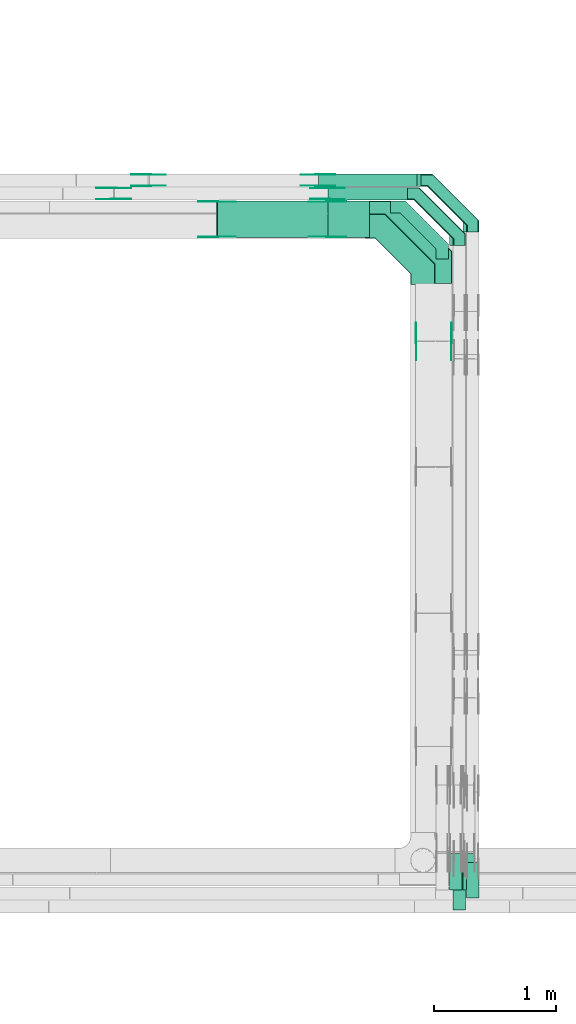
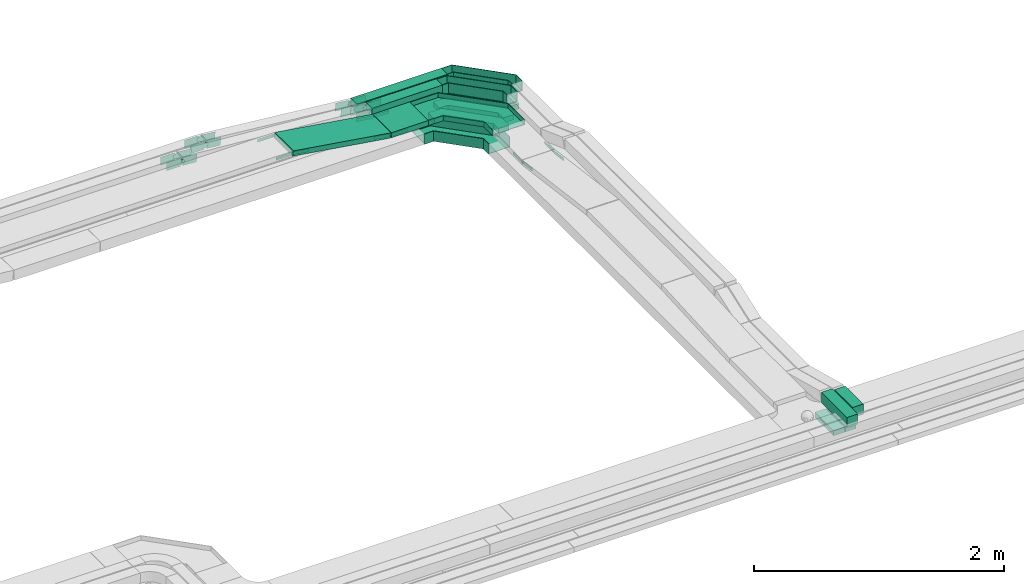
# One storey, part 24 of 32: 35 flow fittings, 8 flow segments.
"""IFC2X3 building model written with IfcOpenShell, lengths in millimetres."""

from ifc_helpers import new_model, entity, si_unit, converted_unit, derived_unit, direction, frame, frame_2d, origin, origin_2d_with_axis, place, context, subcontext, project, spatial, polyline, circle_curve, parameter, trimmed, segment, composite_curve, rectangle, outline, extrude, faceted_brep, source, transform, mapped, material, type_object, type_shapes, element, save


model = new_model("IFC2X3")

# Units and contexts
model_context = context("Model", 3, precision=0.01, world=origin(), true_north=direction((6.12303176911189e-17, 1.0)))
body_context = subcontext(model_context, "Body", "Model", "MODEL_VIEW")
ifc_project = project(units=[si_unit("LENGTHUNIT", "METRE", prefix="MILLI"), si_unit("AREAUNIT", "SQUARE_METRE"), si_unit("VOLUMEUNIT", "CUBIC_METRE"), converted_unit("PLANEANGLEUNIT", "DEGREE", entity("IfcRatioMeasure", 0.0174532925199433), si_unit("PLANEANGLEUNIT", "RADIAN"), dimensions=[0, 0, 0, 0, 0, 0, 0]), si_unit("MASSUNIT", "GRAM", prefix="KILO"), derived_unit("MASSDENSITYUNIT", [(si_unit("MASSUNIT", "GRAM", prefix="KILO"), 1), (si_unit("LENGTHUNIT", "METRE"), -3)]), derived_unit("MOMENTOFINERTIAUNIT", [(si_unit("LENGTHUNIT", "METRE"), 4)]), si_unit("TIMEUNIT", "SECOND"), si_unit("FREQUENCYUNIT", "HERTZ"), si_unit("THERMODYNAMICTEMPERATUREUNIT", "DEGREE_CELSIUS"), derived_unit("THERMALTRANSMITTANCEUNIT", [(si_unit("MASSUNIT", "GRAM", prefix="KILO"), 1), (si_unit("THERMODYNAMICTEMPERATUREUNIT", "KELVIN"), -1), (si_unit("TIMEUNIT", "SECOND"), -3)]), derived_unit("VOLUMETRICFLOWRATEUNIT", [(si_unit("LENGTHUNIT", "METRE"), 3), (si_unit("TIMEUNIT", "SECOND"), -1)]), derived_unit("MASSFLOWRATEUNIT", [(si_unit("MASSUNIT", "GRAM", prefix="KILO"), 1), (si_unit("TIMEUNIT", "SECOND"), -1)]), derived_unit("ROTATIONALFREQUENCYUNIT", [(si_unit("TIMEUNIT", "SECOND"), -1)]), si_unit("ELECTRICCURRENTUNIT", "AMPERE"), si_unit("ELECTRICVOLTAGEUNIT", "VOLT"), si_unit("POWERUNIT", "WATT"), si_unit("FORCEUNIT", "NEWTON", prefix="KILO"), si_unit("ILLUMINANCEUNIT", "LUX"), si_unit("LUMINOUSFLUXUNIT", "LUMEN"), si_unit("LUMINOUSINTENSITYUNIT", "CANDELA"), derived_unit("USERDEFINED", [(si_unit("MASSUNIT", "GRAM", prefix="KILO"), -1), (si_unit("LENGTHUNIT", "METRE"), -2), (si_unit("TIMEUNIT", "SECOND"), 3), (si_unit("LUMINOUSFLUXUNIT", "LUMEN"), 1)]), derived_unit("LINEARVELOCITYUNIT", [(si_unit("LENGTHUNIT", "METRE"), 1), (si_unit("TIMEUNIT", "SECOND"), -1)]), si_unit("PRESSUREUNIT", "PASCAL"), derived_unit("USERDEFINED", [(si_unit("LENGTHUNIT", "METRE"), -2), (si_unit("MASSUNIT", "GRAM", prefix="KILO"), 1), (si_unit("TIMEUNIT", "SECOND"), -2)]), derived_unit("LINEARFORCEUNIT", [(si_unit("MASSUNIT", "GRAM", prefix="KILO"), 1), (si_unit("LENGTHUNIT", "METRE"), 1), (si_unit("TIMEUNIT", "SECOND"), -2), (si_unit("LENGTHUNIT", "METRE"), -1)]), derived_unit("PLANARFORCEUNIT", [(si_unit("MASSUNIT", "GRAM", prefix="KILO"), 1), (si_unit("LENGTHUNIT", "METRE"), 1), (si_unit("TIMEUNIT", "SECOND"), -2), (si_unit("LENGTHUNIT", "METRE"), -2)])], contexts=[model_context])

# Site, building, storey
site_placement = place(None, origin())
site = spatial("IfcSite", under=ifc_project, at=site_placement, CompositionType="ELEMENT")
building_placement = place(site_placement, origin())
building = spatial("IfcBuilding", under=site, at=building_placement, CompositionType="ELEMENT")
storey_placement = place(building_placement, frame((0.0, 0.0, 8100.0)))
storey = spatial("IfcBuildingStorey", under=building, at=storey_placement, CompositionType="ELEMENT", Elevation=8100.0)

# Flow segments
cable_carrier_segment_type = type_object("IfcCableCarrierSegmentType", PredefinedType="CABLETRAYSEGMENT")
flow_segment_1_placement = place(storey_placement, frame((60610.11, 8663.58, 2864.78)))
element("IfcFlowSegment", 1, at=flow_segment_1_placement, inside=storey, type_object=cable_carrier_segment_type, context=body_context, shape_type="SweptSolid", body=[
    extrude(rectangle(XDim=409.510534279909, YDim=99.9999999999946, at=origin_2d_with_axis()), frame((50.0, 204.76, 0.0), z_axis=(0.0, 0.0, 1.0), x_axis=(0.0, -1.0, 0.0)), (0.0, 0.0, 1.0), 99.9999999999989),
])
flow_segment_2_placement = place(storey_placement, frame((60720.11, 8762.63, 2864.81)))
element("IfcFlowSegment", 2, at=flow_segment_2_placement, inside=storey, type_object=cable_carrier_segment_type, context=body_context, shape_type="SweptSolid", body=[
    extrude(rectangle(XDim=289.519566739919, YDim=99.9999999999946, at=origin_2d_with_axis()), frame((50.0, 144.76, 0.0), z_axis=(0.0, 0.0, 1.0), x_axis=(0.0, -1.0, 0.0)), (0.0, 0.0, 1.0), 99.9999999999989),
])
flow_segment_3_placement = place(storey_placement, frame((58669.05, 14182.28, 2715.5)))
element("IfcFlowSegment", 3, at=flow_segment_3_placement, inside=storey, type_object=cable_carrier_segment_type, context=body_context, shape_type="SweptSolid", body=[
    extrude(rectangle(XDim=50.0000000000009, YDim=300.000000000001, at=origin_2d_with_axis()), frame((3.8, 150.0, 163.51), z_axis=(0.988380721010554, 0.0, -0.151998520830492), x_axis=(0.151998520830492, 0.0, 0.988380721010554)), (0.0, 0.0, 1.0), 913.186104856669),
])
flow_segment_4_placement = place(storey_placement, frame((59582.46, 14492.28, 2715.06)))
element("IfcFlowSegment", 4, at=flow_segment_4_placement, inside=storey, type_object=cable_carrier_segment_type, context=body_context, shape_type="SweptSolid", body=[
    extrude(rectangle(XDim=651.643946462782, YDim=99.9999999999989, at=origin_2d_with_axis()), frame((325.82, 50.0, 0.0)), (0.0, 0.0, 1.0), 99.9999999999989),
])
flow_segment_5_placement = place(storey_placement, frame((59505.12, 14602.28, 2715.1)))
element("IfcFlowSegment", 5, at=flow_segment_5_placement, inside=storey, type_object=cable_carrier_segment_type, context=body_context, shape_type="SweptSolid", body=[
    extrude(rectangle(XDim=838.987381608531, YDim=99.9999999999989, at=origin_2d_with_axis()), frame((419.49, 50.0, 0.0)), (0.0, 0.0, 1.0), 99.9999999999993),
])
flow_segment_6_placement = place(storey_placement, frame((60690.11, 8826.03, 2697.68)))
element("IfcFlowSegment", 6, at=flow_segment_6_placement, inside=storey, type_object=cable_carrier_segment_type, context=body_context, shape_type="SweptSolid", body=[
    extrude(rectangle(XDim=300.444409805727, YDim=99.9999999999946, at=origin_2d_with_axis()), frame((50.0, 150.22, 0.0), z_axis=(0.0, 0.0, 1.0), x_axis=(0.0, -1.0, 0.0)), (0.0, 0.0, 1.0), 50.0000000000016),
])
flow_segment_7_placement = place(storey_placement, frame((60580.11, 8826.03, 2697.68)))
element("IfcFlowSegment", 7, at=flow_segment_7_placement, inside=storey, type_object=cable_carrier_segment_type, context=body_context, shape_type="SweptSolid", body=[
    extrude(rectangle(XDim=300.444409805722, YDim=99.9999999999946, at=origin_2d_with_axis()), frame((50.0, 150.22, 0.0), z_axis=(0.0, 0.0, 1.0), x_axis=(0.0, -1.0, 0.0)), (0.0, 0.0, 1.0), 50.0000000000016),
])
flow_segment_8_placement = place(storey_placement, frame((59581.82, 14182.28, 2714.72)))
element("IfcFlowSegment", 8, at=flow_segment_8_placement, inside=storey, type_object=cable_carrier_segment_type, context=body_context, shape_type="SweptSolid", body=[
    extrude(rectangle(XDim=342.285466379996, YDim=300.000000000001, at=origin_2d_with_axis()), frame((171.14, 150.0, 0.0)), (0.0, 0.0, 1.0), 50.0000000000016),
])

# Flow fittings
ifc_material_1 = material()
cable_carrier_fitting_type_1 = type_object("IfcCableCarrierFittingType", Name="470_DKC_G5_Sheet horizontal bend:-", PredefinedType="NOTDEFINED", material=ifc_material_1)
shared_shape_1 = source(origin(), body_context, "Body", "SweptSolid", [
    extrude(outline(polyline([(-238.25, -237.75), (-116.54, -237.75), (237.75, 116.54), (237.75, 238.25), (137.75, 238.25), (137.75, 157.96), (-157.96, -137.75), (-238.25, -137.75), (-238.25, -237.75)])), frame((-187.75, 187.75, -25.0)), (0.0, 0.0, 1.0), 50.0000000000003),
])
type_shapes(cable_carrier_fitting_type_1, [shared_shape_1])
for number, where, z_axis, x_axis, name in (
    (9, (60520.11, 14432.28, 2575.0), (0.0, 0.0, 1.0), (0.0, 1.0, 0.0), "470_DKC_G5_Sheet horizontal bend:-"),
    (10, (60630.11, 14542.28, 2575.0), (0.0, 0.0, 1.0), (0.0, 1.0, 0.0), "470_DKC_G5_Sheet horizontal bend:-"),
    (11, (60740.11, 14652.28, 2575.0), (0.0, 0.0, 1.0), (0.0, 1.0, 0.0), "470_DKC_G5_Sheet horizontal bend:-"),
):
    element("IfcFlowFitting", number, at=place(storey_placement, frame(where, z_axis=z_axis, x_axis=x_axis)), inside=storey, type_object=cable_carrier_fitting_type_1, material=ifc_material_1, Name=name, ObjectType="470_DKC_G5_Sheet horizontal bend:-", context=body_context, shape_type="MappedRepresentation", body=[
        mapped(shared_shape_1, transform((0.0, 0.0, 0.0), scale=1.0)),
    ])
cable_carrier_fitting_type_2 = type_object("IfcCableCarrierFittingType", Name="470_DKC_G5_Sheet horizontal bend:-", PredefinedType="NOTDEFINED", material=ifc_material_1)
shared_shape_2 = source(origin(), body_context, "Body", "Brep", [
    faceted_brep([(-476.0, -100.0, -50.0), (-476.0, -100.0, 50.0), (-476.0, -95.0, 50.0), (-476.0, -95.0, -45.0), (-476.0, 95.0, -45.0), (-476.0, 95.0, 50.0), (-476.0, 100.0, 50.0), (-476.0, 100.0, -50.0), (100.0, 476.0, -50.0), (-100.0, 476.0, -50.0), (-100.0, 476.0, 50.0), (-95.0, 476.0, 50.0), (-95.0, 476.0, -45.0), (95.0, 476.0, -45.0), (95.0, 476.0, 50.0), (100.0, 476.0, 50.0), (-308.58, -100.0, -50.0), (-308.58, -100.0, 50.0), (100.0, 308.58, 50.0), (95.0, 310.65, 50.0), (-310.65, -95.0, 50.0), (-310.65, -95.0, -45.0), (95.0, 310.65, -45.0), (-95.0, 389.35, -45.0), (-389.35, 95.0, -45.0), (-389.35, 95.0, 50.0), (-95.0, 389.35, 50.0), (-100.0, 391.42, 50.0), (-391.42, 100.0, 50.0), (-391.42, 100.0, -50.0), (-100.0, 391.42, -50.0), (100.0, 308.58, -50.0)], [[[0, 1, 2, 3, 4, 5, 6, 7]], [[8, 9, 10, 11, 12, 13, 14, 15]], [[1, 0, 16, 17]], [[2, 1, 17, 18, 15, 14, 19, 20]], [[3, 2, 20, 21]], [[4, 3, 21, 22, 13, 12, 23, 24]], [[5, 4, 24, 25]], [[6, 5, 25, 26, 11, 10, 27, 28]], [[7, 6, 28, 29]], [[0, 7, 29, 30, 9, 8, 31, 16]], [[17, 16, 31, 18]], [[21, 20, 19, 22]], [[25, 24, 23, 26]], [[29, 28, 27, 30]], [[18, 31, 8, 15]], [[22, 19, 14, 13]], [[26, 23, 12, 11]], [[30, 27, 10, 9]]]),
])
type_shapes(cable_carrier_fitting_type_2, [shared_shape_2])
flow_fitting_1_placement = place(storey_placement, frame((60360.11, 14274.5, 2600.0), z_axis=(4.13853607338931e-08, -3.23835000490124e-05, 1.0), x_axis=(0.0, 1.0, 3.23835000490124e-05)))
element("IfcFlowFitting", 12, at=flow_fitting_1_placement, inside=storey, type_object=cable_carrier_fitting_type_2, material=ifc_material_1, Name="470_DKC_G5_Sheet horizontal bend:-", ObjectType="470_DKC_G5_Sheet horizontal bend:-", context=body_context, shape_type="MappedRepresentation", body=[
    mapped(shared_shape_2, transform((0.0, 0.0, 0.0), scale=1.0)),
])
cable_carrier_fitting_type_3 = type_object("IfcCableCarrierFittingType", Name="470_DKC_G5_Sheet horizontal bend:-", PredefinedType="NOTDEFINED", material=ifc_material_1)
shared_shape_3 = source(origin(), body_context, "Body", "Brep", [
    faceted_brep([(-426.0, -50.0, -50.0), (-426.0, -50.0, 50.0), (-426.0, -45.0, 50.0), (-426.0, -45.0, -45.0), (-426.0, 45.0, -45.0), (-426.0, 45.0, 50.0), (-426.0, 50.0, 50.0), (-426.0, 50.0, -50.0), (50.0, 426.0, -50.0), (-50.0, 426.0, -50.0), (-50.0, 426.0, 50.0), (-45.0, 426.0, 50.0), (-45.0, 426.0, -45.0), (45.0, 426.0, -45.0), (45.0, 426.0, 50.0), (50.0, 426.0, 50.0), (-329.29, -50.0, -50.0), (-329.29, -50.0, 50.0), (50.0, 329.29, 50.0), (45.0, 331.36, 50.0), (-331.36, -45.0, 50.0), (-331.36, -45.0, -45.0), (45.0, 331.36, -45.0), (-45.0, 368.64, -45.0), (-368.64, 45.0, -45.0), (-368.64, 45.0, 50.0), (-45.0, 368.64, 50.0), (-50.0, 370.71, 50.0), (-370.71, 50.0, 50.0), (-370.71, 50.0, -50.0), (-50.0, 370.71, -50.0), (50.0, 329.29, -50.0)], [[[0, 1, 2, 3, 4, 5, 6, 7]], [[8, 9, 10, 11, 12, 13, 14, 15]], [[1, 0, 16, 17]], [[2, 1, 17, 18, 15, 14, 19, 20]], [[3, 2, 20, 21]], [[4, 3, 21, 22, 13, 12, 23, 24]], [[5, 4, 24, 25]], [[6, 5, 25, 26, 11, 10, 27, 28]], [[7, 6, 28, 29]], [[0, 7, 29, 30, 9, 8, 31, 16]], [[17, 16, 31, 18]], [[21, 20, 19, 22]], [[25, 24, 23, 26]], [[29, 28, 27, 30]], [[18, 31, 8, 15]], [[22, 19, 14, 13]], [[26, 23, 12, 11]], [[30, 27, 10, 9]]]),
])
type_shapes(cable_carrier_fitting_type_3, [shared_shape_3])
for number, where, z_axis, x_axis, name in (
    (13, (60770.11, 14652.28, 2765.1), (8.27111670022524e-08, -3.35252266217633e-05, 1.0), (0.0, 1.0, 3.35252266217634e-05), "470_DKC_G5_Sheet horizontal bend:-"),
    (14, (60660.11, 14542.28, 2765.06), (0.0, 0.0, 1.0), (0.0, 1.0, 0.0), "470_DKC_G5_Sheet horizontal bend:-"),
):
    element("IfcFlowFitting", number, at=place(storey_placement, frame(where, z_axis=z_axis, x_axis=x_axis)), inside=storey, type_object=cable_carrier_fitting_type_3, material=ifc_material_1, Name=name, ObjectType="470_DKC_G5_Sheet horizontal bend:-", context=body_context, shape_type="MappedRepresentation", body=[
        mapped(shared_shape_3, transform((0.0, 0.0, 0.0), scale=1.0)),
    ])
cable_carrier_fitting_type_4 = type_object("IfcCableCarrierFittingType", Name="470_DKC_G5_Sheet horizontal bend:-", PredefinedType="NOTDEFINED", material=ifc_material_1)
shared_shape_4 = source(origin(), body_context, "Body", "Brep", [
    faceted_brep([(-526.0, -150.0, -25.0), (-526.0, -150.0, 25.0), (-526.0, -145.0, 25.0), (-526.0, -145.0, -20.0), (-526.0, 145.0, -20.0), (-526.0, 145.0, 25.0), (-526.0, 150.0, 25.0), (-526.0, 150.0, -25.0), (150.0, 526.0, -25.0), (-150.0, 526.0, -25.0), (-150.0, 526.0, 25.0), (-145.0, 526.0, 25.0), (-145.0, 526.0, -20.0), (145.0, 526.0, -20.0), (145.0, 526.0, 25.0), (150.0, 526.0, 25.0), (-262.87, -150.0, -25.0), (-262.87, -150.0, 25.0), (150.0, 262.87, 25.0), (145.0, 264.94, 25.0), (-264.94, -145.0, 25.0), (-264.94, -145.0, -20.0), (145.0, 264.94, -20.0), (-145.0, 385.06, -20.0), (-385.06, 145.0, -20.0), (-385.06, 145.0, 25.0), (-145.0, 385.06, 25.0), (-150.0, 387.13, 25.0), (-387.13, 150.0, 25.0), (-387.13, 150.0, -25.0), (-150.0, 387.13, -25.0), (150.0, 262.87, -25.0)], [[[0, 1, 2, 3, 4, 5, 6, 7]], [[8, 9, 10, 11, 12, 13, 14, 15]], [[1, 0, 16, 17]], [[2, 1, 17, 18, 15, 14, 19, 20]], [[3, 2, 20, 21]], [[4, 3, 21, 22, 13, 12, 23, 24]], [[5, 4, 24, 25]], [[6, 5, 25, 26, 11, 10, 27, 28]], [[7, 6, 28, 29]], [[0, 7, 29, 30, 9, 8, 31, 16]], [[17, 16, 31, 18]], [[21, 20, 19, 22]], [[25, 24, 23, 26]], [[29, 28, 27, 30]], [[18, 31, 8, 15]], [[22, 19, 14, 13]], [[26, 23, 12, 11]], [[30, 27, 10, 9]]]),
])
type_shapes(cable_carrier_fitting_type_4, [shared_shape_4])
flow_fitting_2_placement = place(storey_placement, frame((60450.11, 14332.28, 2739.72), z_axis=(0.0, 0.0, 1.0), x_axis=(0.0, 1.0, 0.0)))
element("IfcFlowFitting", 15, at=flow_fitting_2_placement, inside=storey, type_object=cable_carrier_fitting_type_4, material=ifc_material_1, Name="470_DKC_G5_Sheet horizontal bend:-", ObjectType="470_DKC_G5_Sheet horizontal bend:-", context=body_context, shape_type="MappedRepresentation", body=[
    mapped(shared_shape_4, transform((0.0, 0.0, 0.0), scale=1.0)),
])
ifc_material_2 = material(Name="G")
cable_carrier_fitting_type_5 = type_object("IfcCableCarrierFittingType", PredefinedType="NOTDEFINED", material=ifc_material_2)
shared_shape_5 = source(origin(), body_context, "Body", "SweptSolid", [
    extrude(outline(composite_curve([segment(trimmed(circle_curve(frame_2d((-44.59, 0.0), x_axis=(1.0, 0.0)), 12.5), [parameter(90.0000000000007)], [parameter(270.0)], True, "PARAMETER"), True, "CONTINUOUS"), segment(polyline([(-44.59, -12.5), (-33.09, -12.5)]), True, "CONTINUOUS"), segment(polyline([(-33.09, -12.5), (-31.23, -14.5)]), True, "CONTINUOUS"), segment(polyline([(-31.23, -14.5), (108.91, -14.5)]), True, "CONTINUOUS"), segment(polyline([(108.91, -14.5), (108.91, 14.5)]), True, "CONTINUOUS"), segment(polyline([(108.91, 14.5), (-31.23, 14.5)]), True, "CONTINUOUS"), segment(polyline([(-31.23, 14.5), (-33.09, 12.5)]), True, "CONTINUOUS"), segment(polyline([(-33.09, 12.5), (-44.59, 12.5)]), True, "CONTINUOUS")], self_intersect=False)), frame((44.59, 0.0, 0.0), z_axis=(0.0, 0.0, -1.0), x_axis=(1.0, 0.0, 0.0)), (0.0, 0.0, -1.0), 2.0),
])
type_shapes(cable_carrier_fitting_type_5, [shared_shape_5])
flow_fitting_3_placement = place(storey_placement, frame((58669.67, 14186.82, 2879.5), z_axis=(0.0, -1.0, 0.0), x_axis=(-1.0, 0.0, 0.0)))
element("IfcFlowFitting", 16, at=flow_fitting_3_placement, inside=storey, type_object=cable_carrier_fitting_type_5, material=ifc_material_2, context=body_context, shape_type="MappedRepresentation", body=[
    mapped(shared_shape_5, transform((0.0, 0.0, 0.0), scale=1.0)),
])
cable_carrier_fitting_type_6 = type_object("IfcCableCarrierFittingType", PredefinedType="NOTDEFINED", material=ifc_material_2)
type_shapes(cable_carrier_fitting_type_6, [shared_shape_5])
flow_fitting_4_placement = place(storey_placement, frame((58669.67, 14475.74, 2879.5), z_axis=(0.0, 1.0, 0.0), x_axis=(0.98838072101055, 0.0, -0.151998520830521)))
element("IfcFlowFitting", 17, at=flow_fitting_4_placement, inside=storey, type_object=cable_carrier_fitting_type_6, material=ifc_material_2, context=body_context, shape_type="MappedRepresentation", body=[
    mapped(shared_shape_5, transform((0.0, 0.0, 0.0), scale=1.0)),
])
flow_fitting_5_placement = place(storey_placement, frame((60595.57, 13328.21, 2739.72), z_axis=(1.0, 0.0, 0.0), x_axis=(0.0, 1.0, 0.0)))
element("IfcFlowFitting", 18, at=flow_fitting_5_placement, inside=storey, type_object=cable_carrier_fitting_type_5, material=ifc_material_2, context=body_context, shape_type="MappedRepresentation", body=[
    mapped(shared_shape_5, transform((0.0, 0.0, 0.0), scale=1.0)),
])
flow_fitting_6_placement = place(storey_placement, frame((60306.65, 13328.21, 2739.72), z_axis=(-1.0, 0.0, 0.0), x_axis=(0.0, -0.991519700782225, 0.129956465636488)))
element("IfcFlowFitting", 19, at=flow_fitting_6_placement, inside=storey, type_object=cable_carrier_fitting_type_6, material=ifc_material_2, context=body_context, shape_type="MappedRepresentation", body=[
    mapped(shared_shape_5, transform((0.0, 0.0, 0.0), scale=1.0)),
])
flow_fitting_7_placement = place(storey_placement, frame((59578.61, 14186.82, 2739.72), z_axis=(0.0, -1.0, 0.0), x_axis=(1.0, 0.0, 0.0)))
element("IfcFlowFitting", 20, at=flow_fitting_7_placement, inside=storey, type_object=cable_carrier_fitting_type_5, material=ifc_material_2, context=body_context, shape_type="MappedRepresentation", body=[
    mapped(shared_shape_5, transform((0.0, 0.0, 0.0), scale=1.0)),
])
flow_fitting_8_placement = place(storey_placement, frame((59578.61, 14475.74, 2739.72), z_axis=(0.0, 1.0, 0.0), x_axis=(-0.98838072101055, 0.0, 0.151998520830518)))
element("IfcFlowFitting", 21, at=flow_fitting_8_placement, inside=storey, type_object=cable_carrier_fitting_type_6, material=ifc_material_2, context=body_context, shape_type="MappedRepresentation", body=[
    mapped(shared_shape_5, transform((0.0, 0.0, 0.0), scale=1.0)),
])
cable_carrier_fitting_type_7 = type_object("IfcCableCarrierFittingType", PredefinedType="NOTDEFINED", material=ifc_material_2)
shared_shape_6 = source(origin(), body_context, "Body", "SweptSolid", [
    extrude(outline(composite_curve([segment(trimmed(circle_curve(frame_2d((-44.59, 0.0), x_axis=(1.0, 0.0)), 12.5), [parameter(90.0000000000007)], [parameter(270.0)], True, "PARAMETER"), True, "CONTINUOUS"), segment(polyline([(-44.59, -12.5), (-33.09, -12.5)]), True, "CONTINUOUS"), segment(polyline([(-33.09, -12.5), (-31.23, -14.5)]), True, "CONTINUOUS"), segment(polyline([(-31.23, -14.5), (108.91, -14.5)]), True, "CONTINUOUS"), segment(polyline([(108.91, -14.5), (108.91, 14.5)]), True, "CONTINUOUS"), segment(polyline([(108.91, 14.5), (-31.23, 14.5)]), True, "CONTINUOUS"), segment(polyline([(-31.23, 14.5), (-33.09, 12.5)]), True, "CONTINUOUS"), segment(polyline([(-33.09, 12.5), (-44.59, 12.5)]), True, "CONTINUOUS")], self_intersect=False)), frame((44.59, 0.0, 0.0)), (0.0, 0.0, 1.0), 2.0),
])
type_shapes(cable_carrier_fitting_type_7, [shared_shape_6])
flow_fitting_9_placement = place(storey_placement, frame((58669.67, 14477.74, 2879.5), z_axis=(0.0, 1.0, 0.0), x_axis=(-1.0, 0.0, 0.0)))
element("IfcFlowFitting", 22, at=flow_fitting_9_placement, inside=storey, type_object=cable_carrier_fitting_type_7, material=ifc_material_2, context=body_context, shape_type="MappedRepresentation", body=[
    mapped(shared_shape_6, transform((0.0, 0.0, 0.0), scale=1.0)),
])
cable_carrier_fitting_type_8 = type_object("IfcCableCarrierFittingType", PredefinedType="NOTDEFINED", material=ifc_material_2)
type_shapes(cable_carrier_fitting_type_8, [shared_shape_6])
flow_fitting_10_placement = place(storey_placement, frame((58669.67, 14188.82, 2879.5), z_axis=(0.0, -1.0, 0.0), x_axis=(0.98838072101055, 0.0, -0.151998520830521)))
element("IfcFlowFitting", 23, at=flow_fitting_10_placement, inside=storey, type_object=cable_carrier_fitting_type_8, material=ifc_material_2, context=body_context, shape_type="MappedRepresentation", body=[
    mapped(shared_shape_6, transform((0.0, 0.0, 0.0), scale=1.0)),
])
flow_fitting_11_placement = place(storey_placement, frame((60304.65, 13328.21, 2739.72), z_axis=(-1.0, 0.0, 0.0), x_axis=(0.0, 1.0, 0.0)))
element("IfcFlowFitting", 24, at=flow_fitting_11_placement, inside=storey, type_object=cable_carrier_fitting_type_7, material=ifc_material_2, context=body_context, shape_type="MappedRepresentation", body=[
    mapped(shared_shape_6, transform((0.0, 0.0, 0.0), scale=1.0)),
])
flow_fitting_12_placement = place(storey_placement, frame((60593.57, 13328.21, 2739.72), z_axis=(1.0, 0.0, 0.0), x_axis=(0.0, -0.991519700782225, 0.129956465636488)))
element("IfcFlowFitting", 25, at=flow_fitting_12_placement, inside=storey, type_object=cable_carrier_fitting_type_8, material=ifc_material_2, context=body_context, shape_type="MappedRepresentation", body=[
    mapped(shared_shape_6, transform((0.0, 0.0, 0.0), scale=1.0)),
])
flow_fitting_13_placement = place(storey_placement, frame((59578.61, 14477.74, 2739.72), z_axis=(0.0, 1.0, 0.0), x_axis=(1.0, 0.0, 0.0)))
element("IfcFlowFitting", 26, at=flow_fitting_13_placement, inside=storey, type_object=cable_carrier_fitting_type_7, material=ifc_material_2, context=body_context, shape_type="MappedRepresentation", body=[
    mapped(shared_shape_6, transform((0.0, 0.0, 0.0), scale=1.0)),
])
flow_fitting_14_placement = place(storey_placement, frame((59578.61, 14188.82, 2739.72), z_axis=(0.0, -1.0, 0.0), x_axis=(-0.98838072101055, 0.0, 0.151998520830518)))
element("IfcFlowFitting", 27, at=flow_fitting_14_placement, inside=storey, type_object=cable_carrier_fitting_type_8, material=ifc_material_2, context=body_context, shape_type="MappedRepresentation", body=[
    mapped(shared_shape_6, transform((0.0, 0.0, 0.0), scale=1.0)),
])
cable_carrier_fitting_type_9 = type_object("IfcCableCarrierFittingType", PredefinedType="NOTDEFINED", material=ifc_material_2)
shared_shape_7 = source(origin(), body_context, "Body", "SweptSolid", [
    extrude(outline(composite_curve([segment(trimmed(circle_curve(frame_2d((-41.47, 0.0), x_axis=(1.0, 0.0)), 25.0), [parameter(90.0000000000007)], [parameter(270.0)], True, "PARAMETER"), True, "CONTINUOUS"), segment(polyline([(-41.47, -25.0), (-29.97, -25.0)]), True, "CONTINUOUS"), segment(polyline([(-29.97, -25.0), (-28.1, -38.5)]), True, "CONTINUOUS"), segment(polyline([(-28.1, -38.5), (99.53, -38.5)]), True, "CONTINUOUS"), segment(polyline([(99.53, -38.5), (99.53, 38.5)]), True, "CONTINUOUS"), segment(polyline([(99.53, 38.5), (-28.1, 38.5)]), True, "CONTINUOUS"), segment(polyline([(-28.1, 38.5), (-29.97, 25.0)]), True, "CONTINUOUS"), segment(polyline([(-29.97, 25.0), (-41.47, 25.0)]), True, "CONTINUOUS")], self_intersect=False)), frame((41.47, 0.0, 0.0), z_axis=(0.0, 0.0, -1.0), x_axis=(1.0, 0.0, 0.0)), (0.0, 0.0, -1.0), 2.0),
])
type_shapes(cable_carrier_fitting_type_9, [shared_shape_7])
flow_fitting_15_placement = place(storey_placement, frame((57822.91, 14496.82, 2905.0), z_axis=(0.0, -1.0, 0.0), x_axis=(-1.0, 0.0, 0.0)))
element("IfcFlowFitting", 28, at=flow_fitting_15_placement, inside=storey, type_object=cable_carrier_fitting_type_9, material=ifc_material_2, context=body_context, shape_type="MappedRepresentation", body=[
    mapped(shared_shape_7, transform((0.0, 0.0, 0.0), scale=1.0)),
])
cable_carrier_fitting_type_10 = type_object("IfcCableCarrierFittingType", PredefinedType="NOTDEFINED", material=ifc_material_2)
type_shapes(cable_carrier_fitting_type_10, [shared_shape_7])
flow_fitting_16_placement = place(storey_placement, frame((57822.91, 14585.74, 2905.0), z_axis=(0.0, 1.0, 0.0), x_axis=(0.996841183853236, 0.0, -0.0794207414601401)))
element("IfcFlowFitting", 29, at=flow_fitting_16_placement, inside=storey, type_object=cable_carrier_fitting_type_10, material=ifc_material_2, context=body_context, shape_type="MappedRepresentation", body=[
    mapped(shared_shape_7, transform((0.0, 0.0, 0.0), scale=1.0)),
])
flow_fitting_17_placement = place(storey_placement, frame((58106.41, 14606.82, 2905.0), z_axis=(0.0, -1.0, 0.0), x_axis=(-1.0, 0.0, 0.0)))
element("IfcFlowFitting", 30, at=flow_fitting_17_placement, inside=storey, type_object=cable_carrier_fitting_type_9, material=ifc_material_2, context=body_context, shape_type="MappedRepresentation", body=[
    mapped(shared_shape_7, transform((0.0, 0.0, 0.0), scale=1.0)),
])
flow_fitting_18_placement = place(storey_placement, frame((58106.41, 14695.74, 2905.0), z_axis=(0.0, 1.0, 0.0), x_axis=(0.995008976454974, 0.0, -0.0997854537195949)))
element("IfcFlowFitting", 31, at=flow_fitting_18_placement, inside=storey, type_object=cable_carrier_fitting_type_10, material=ifc_material_2, context=body_context, shape_type="MappedRepresentation", body=[
    mapped(shared_shape_7, transform((0.0, 0.0, 0.0), scale=1.0)),
])
flow_fitting_19_placement = place(storey_placement, frame((59501.42, 14606.82, 2765.1), z_axis=(0.0, -1.0, 0.0), x_axis=(1.0, 0.0, -8.27111719114981e-08)))
element("IfcFlowFitting", 32, at=flow_fitting_19_placement, inside=storey, type_object=cable_carrier_fitting_type_9, material=ifc_material_2, context=body_context, shape_type="MappedRepresentation", body=[
    mapped(shared_shape_7, transform((0.0, 0.0, 0.0), scale=1.0)),
])
flow_fitting_20_placement = place(storey_placement, frame((59501.42, 14695.74, 2765.1), z_axis=(0.0, 1.0, 0.0), x_axis=(-0.995008976454974, 0.0, 0.0997854537195905)))
element("IfcFlowFitting", 33, at=flow_fitting_20_placement, inside=storey, type_object=cable_carrier_fitting_type_10, material=ifc_material_2, context=body_context, shape_type="MappedRepresentation", body=[
    mapped(shared_shape_7, transform((0.0, 0.0, 0.0), scale=1.0)),
])
flow_fitting_21_placement = place(storey_placement, frame((59579.32, 14496.82, 2765.06), z_axis=(0.0, -1.0, 0.0), x_axis=(1.0, 0.0, 0.0)))
element("IfcFlowFitting", 34, at=flow_fitting_21_placement, inside=storey, type_object=cable_carrier_fitting_type_9, material=ifc_material_2, context=body_context, shape_type="MappedRepresentation", body=[
    mapped(shared_shape_7, transform((0.0, 0.0, 0.0), scale=1.0)),
])
flow_fitting_22_placement = place(storey_placement, frame((59579.32, 14585.74, 2765.06), z_axis=(0.0, 1.0, 0.0), x_axis=(-0.996841183853237, 0.0, 0.0794207414601364)))
element("IfcFlowFitting", 35, at=flow_fitting_22_placement, inside=storey, type_object=cable_carrier_fitting_type_10, material=ifc_material_2, context=body_context, shape_type="MappedRepresentation", body=[
    mapped(shared_shape_7, transform((0.0, 0.0, 0.0), scale=1.0)),
])
cable_carrier_fitting_type_11 = type_object("IfcCableCarrierFittingType", PredefinedType="NOTDEFINED", material=ifc_material_2)
shared_shape_8 = source(origin(), body_context, "Body", "SweptSolid", [
    extrude(outline(composite_curve([segment(trimmed(circle_curve(frame_2d((-41.47, 0.0), x_axis=(1.0, 0.0)), 25.0), [parameter(90.0000000000007)], [parameter(270.0)], True, "PARAMETER"), True, "CONTINUOUS"), segment(polyline([(-41.47, -25.0), (-29.97, -25.0)]), True, "CONTINUOUS"), segment(polyline([(-29.97, -25.0), (-28.1, -38.5)]), True, "CONTINUOUS"), segment(polyline([(-28.1, -38.5), (99.53, -38.5)]), True, "CONTINUOUS"), segment(polyline([(99.53, -38.5), (99.53, 38.5)]), True, "CONTINUOUS"), segment(polyline([(99.53, 38.5), (-28.1, 38.5)]), True, "CONTINUOUS"), segment(polyline([(-28.1, 38.5), (-29.97, 25.0)]), True, "CONTINUOUS"), segment(polyline([(-29.97, 25.0), (-41.47, 25.0)]), True, "CONTINUOUS")], self_intersect=False)), frame((41.47, 0.0, 0.0)), (0.0, 0.0, 1.0), 2.0),
])
type_shapes(cable_carrier_fitting_type_11, [shared_shape_8])
flow_fitting_23_placement = place(storey_placement, frame((57822.91, 14587.74, 2905.0), z_axis=(0.0, 1.0, 0.0), x_axis=(-1.0, 0.0, 0.0)))
element("IfcFlowFitting", 36, at=flow_fitting_23_placement, inside=storey, type_object=cable_carrier_fitting_type_11, material=ifc_material_2, context=body_context, shape_type="MappedRepresentation", body=[
    mapped(shared_shape_8, transform((0.0, 0.0, 0.0), scale=1.0)),
])
cable_carrier_fitting_type_12 = type_object("IfcCableCarrierFittingType", PredefinedType="NOTDEFINED", material=ifc_material_2)
type_shapes(cable_carrier_fitting_type_12, [shared_shape_8])
flow_fitting_24_placement = place(storey_placement, frame((57822.91, 14498.82, 2905.0), z_axis=(0.0, -1.0, 0.0), x_axis=(0.996841183853236, 0.0, -0.0794207414601401)))
element("IfcFlowFitting", 37, at=flow_fitting_24_placement, inside=storey, type_object=cable_carrier_fitting_type_12, material=ifc_material_2, context=body_context, shape_type="MappedRepresentation", body=[
    mapped(shared_shape_8, transform((0.0, 0.0, 0.0), scale=1.0)),
])
flow_fitting_25_placement = place(storey_placement, frame((58106.41, 14697.74, 2905.0), z_axis=(0.0, 1.0, 0.0), x_axis=(-1.0, 0.0, 0.0)))
element("IfcFlowFitting", 38, at=flow_fitting_25_placement, inside=storey, type_object=cable_carrier_fitting_type_11, material=ifc_material_2, context=body_context, shape_type="MappedRepresentation", body=[
    mapped(shared_shape_8, transform((0.0, 0.0, 0.0), scale=1.0)),
])
flow_fitting_26_placement = place(storey_placement, frame((58106.41, 14608.82, 2905.0), z_axis=(0.0, -1.0, 0.0), x_axis=(0.995008976454974, 0.0, -0.0997854537195949)))
element("IfcFlowFitting", 39, at=flow_fitting_26_placement, inside=storey, type_object=cable_carrier_fitting_type_12, material=ifc_material_2, context=body_context, shape_type="MappedRepresentation", body=[
    mapped(shared_shape_8, transform((0.0, 0.0, 0.0), scale=1.0)),
])
flow_fitting_27_placement = place(storey_placement, frame((59501.42, 14697.74, 2765.1), z_axis=(0.0, 1.0, 0.0), x_axis=(1.0, 0.0, -8.27111719114981e-08)))
element("IfcFlowFitting", 40, at=flow_fitting_27_placement, inside=storey, type_object=cable_carrier_fitting_type_11, material=ifc_material_2, context=body_context, shape_type="MappedRepresentation", body=[
    mapped(shared_shape_8, transform((0.0, 0.0, 0.0), scale=1.0)),
])
flow_fitting_28_placement = place(storey_placement, frame((59501.42, 14608.82, 2765.1), z_axis=(0.0, -1.0, 0.0), x_axis=(-0.995008976454974, 0.0, 0.0997854537195905)))
element("IfcFlowFitting", 41, at=flow_fitting_28_placement, inside=storey, type_object=cable_carrier_fitting_type_12, material=ifc_material_2, context=body_context, shape_type="MappedRepresentation", body=[
    mapped(shared_shape_8, transform((0.0, 0.0, 0.0), scale=1.0)),
])
flow_fitting_29_placement = place(storey_placement, frame((59579.32, 14587.74, 2765.06), z_axis=(0.0, 1.0, 0.0), x_axis=(1.0, 0.0, 0.0)))
element("IfcFlowFitting", 42, at=flow_fitting_29_placement, inside=storey, type_object=cable_carrier_fitting_type_11, material=ifc_material_2, context=body_context, shape_type="MappedRepresentation", body=[
    mapped(shared_shape_8, transform((0.0, 0.0, 0.0), scale=1.0)),
])
flow_fitting_30_placement = place(storey_placement, frame((59579.32, 14498.82, 2765.06), z_axis=(0.0, -1.0, 0.0), x_axis=(-0.996841183853237, 0.0, 0.0794207414601364)))
element("IfcFlowFitting", 43, at=flow_fitting_30_placement, inside=storey, type_object=cable_carrier_fitting_type_12, material=ifc_material_2, context=body_context, shape_type="MappedRepresentation", body=[
    mapped(shared_shape_8, transform((0.0, 0.0, 0.0), scale=1.0)),
])

save(model, "model.ifc")
